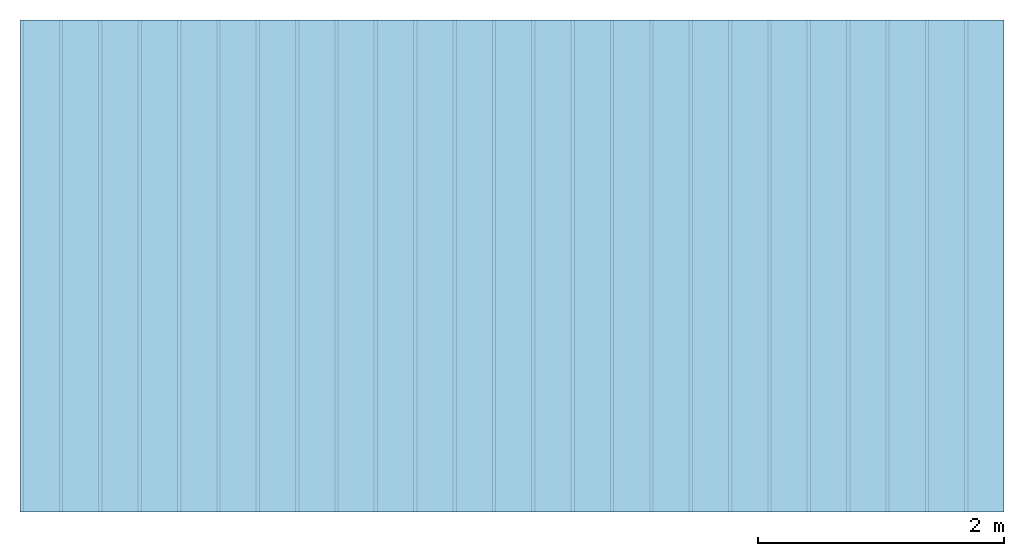
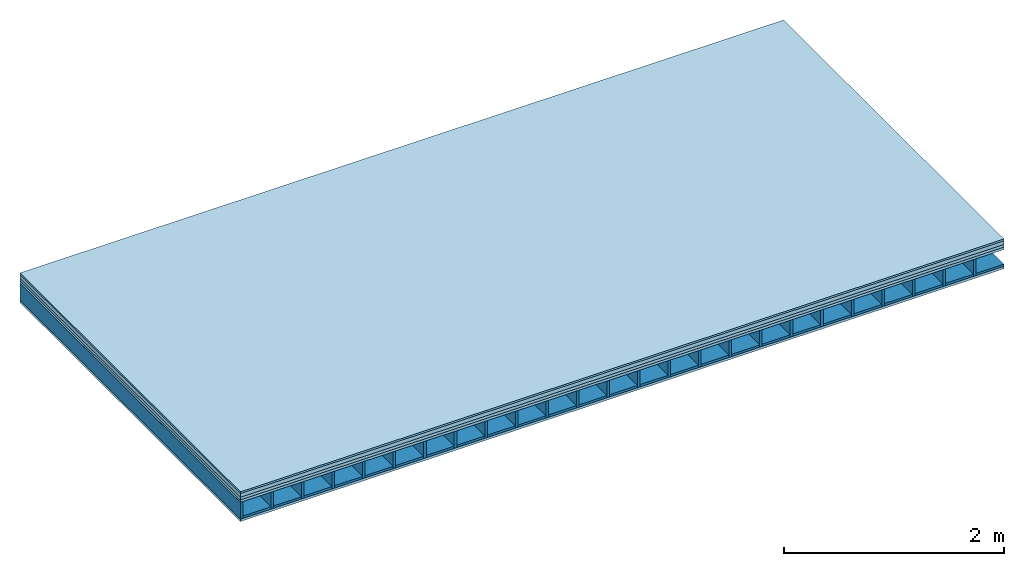
# One storey: 5 plates, 2 members, 1 element without a shape of its own.
"""IFC4 building model written with IfcOpenShell, lengths in metres."""

from ifc_helpers import new_model, si_unit, derived_unit, direction, frame, frame_2d, origin, origin_with_axes, place, context, project, spatial, rectangle, extrude, material, layer, layer_set, type_object, element, aggregate, save


model = new_model("IFC4")

# Units and contexts
plan_context = context("Plan", 3, precision=1e-05, world=origin(), true_north=direction((0.0, 1.0)))
model_context = context("Model", 3, precision=1e-05, world=origin(), true_north=direction((0.0, 1.0)))
ifc_project = project(units=[si_unit("LENGTHUNIT", "METRE"), derived_unit("SOUNDPRESSUREUNIT", [(si_unit("PRESSUREUNIT", "PASCAL", prefix="MICRO"), 0)]), si_unit("ENERGYUNIT", "JOULE", prefix="MEGA"), si_unit("MASSUNIT", "GRAM", prefix="KILO"), derived_unit("THERMALTRANSMITTANCEUNIT", [(si_unit("POWERUNIT", "WATT"), 1), (si_unit("AREAUNIT", "SQUARE_METRE"), -1), (si_unit("THERMODYNAMICTEMPERATUREUNIT", "KELVIN"), -1)]), derived_unit("AREADENSITYUNIT", [(si_unit("MASSUNIT", "GRAM", prefix="KILO"), 1), (si_unit("AREAUNIT", "SQUARE_METRE"), -1)]), derived_unit("USERDEFINED", [(si_unit("ENERGYUNIT", "JOULE", prefix="MEGA"), 1), (si_unit("AREAUNIT", "SQUARE_METRE"), -1)])], contexts=[plan_context, model_context])

# Site, building, storey
site = spatial("IfcSite", under=ifc_project)
building_placement = place(None, origin())
building = spatial("IfcBuilding", under=site, at=building_placement)
storey_placement = place(building_placement, origin())
storey = spatial("IfcBuildingStorey", under=building, at=storey_placement)

# Slab, members, plates
ifc_material_1 = material(Category="03.007")
ifc_layer_1 = layer(ifc_material_1, 0.02, Name="On-material")
ifc_material_2 = material(Name="internal", Category="10.009")
ifc_layer_2 = layer(ifc_material_2, 0.04, Name="Impact sound insulation")
ifc_material_3 = material(Name="with broken")
ifc_layer_3 = layer(ifc_material_3, 0.03, Name="on Supporting structure")
ifc_material_4 = material(Name="3-layer board Spruce Nova Top", Category="07.001")
ifc_layer_4 = layer(ifc_material_4, 0.027, Name="Sub-floor")
ifc_material_5 = material(Name="Rigid, of the art")
ifc_layer_5 = layer(ifc_material_5, 0.0, Name="Bond")
ifc_layer_6 = layer(None, 0.186, Name="Supporting structure")
ifc_layer_7 = layer(ifc_material_5, 0.0, Name="Bond")
ifc_layer_8 = layer(ifc_material_4, 0.027, Name="Lower layer 1")
ifc_layer_set = layer_set([ifc_layer_1, ifc_layer_2, ifc_layer_3, ifc_layer_4, ifc_layer_5, ifc_layer_6, ifc_layer_7, ifc_layer_8])
slab_type = type_object("IfcSlabType", Name="A0015", PredefinedType="NOTDEFINED", material=ifc_layer_set)
slab_placement = place(None, frame((0.0, 0.0, 0.0), z_axis=(0.0, 0.0, -1.0), x_axis=(1.0, 0.0, 0.0)))
slab = element("IfcSlab", 1, at=slab_placement, inside=storey, type_object=slab_type, material=ifc_layer_set, Name="Slab #1")
ifc_material_6 = material()
member_1_placement = place(slab_placement, origin())
member_1 = element("IfcMember", 2, at=member_1_placement, material=ifc_material_6, Name="Supporting structure", context=plan_context, shape_type="SweptSolid", body=[
    extrude(rectangle(XDim=0.027, YDim=0.186, at=frame_2d((0.0135, 0.093), x_axis=(1.0, 0.0))), frame((0.0, 4.0, 0.117), z_axis=(0.0, -1.0, 0.0), x_axis=(1.0, 0.0, 0.0)), (0.0, 0.0, 1.0), 4.0),
    extrude(rectangle(XDim=0.027, YDim=0.186, at=frame_2d((0.0135, 0.093), x_axis=(1.0, 0.0))), frame((0.32, 4.0, 0.117), z_axis=(0.0, -1.0, 0.0), x_axis=(1.0, 0.0, 0.0)), (0.0, 0.0, 1.0), 4.0),
    extrude(rectangle(XDim=0.027, YDim=0.186, at=frame_2d((0.0135, 0.093), x_axis=(1.0, 0.0))), frame((0.64, 4.0, 0.117), z_axis=(0.0, -1.0, 0.0), x_axis=(1.0, 0.0, 0.0)), (0.0, 0.0, 1.0), 4.0),
    extrude(rectangle(XDim=0.027, YDim=0.186, at=frame_2d((0.0135, 0.093), x_axis=(1.0, 0.0))), frame((0.96, 4.0, 0.117), z_axis=(0.0, -1.0, 0.0), x_axis=(1.0, 0.0, 0.0)), (0.0, 0.0, 1.0), 4.0),
    extrude(rectangle(XDim=0.027, YDim=0.186, at=frame_2d((0.0135, 0.093), x_axis=(1.0, 0.0))), frame((1.28, 4.0, 0.117), z_axis=(0.0, -1.0, 0.0), x_axis=(1.0, 0.0, 0.0)), (0.0, 0.0, 1.0), 4.0),
    extrude(rectangle(XDim=0.027, YDim=0.186, at=frame_2d((0.0135, 0.093), x_axis=(1.0, 0.0))), frame((1.6, 4.0, 0.117), z_axis=(0.0, -1.0, 0.0), x_axis=(1.0, 0.0, 0.0)), (0.0, 0.0, 1.0), 4.0),
    extrude(rectangle(XDim=0.027, YDim=0.186, at=frame_2d((0.0135, 0.093), x_axis=(1.0, 0.0))), frame((1.92, 4.0, 0.117), z_axis=(0.0, -1.0, 0.0), x_axis=(1.0, 0.0, 0.0)), (0.0, 0.0, 1.0), 4.0),
    extrude(rectangle(XDim=0.027, YDim=0.186, at=frame_2d((0.0135, 0.093), x_axis=(1.0, 0.0))), frame((2.24, 4.0, 0.117), z_axis=(0.0, -1.0, 0.0), x_axis=(1.0, 0.0, 0.0)), (0.0, 0.0, 1.0), 4.0),
    extrude(rectangle(XDim=0.027, YDim=0.186, at=frame_2d((0.0135, 0.093), x_axis=(1.0, 0.0))), frame((2.56, 4.0, 0.117), z_axis=(0.0, -1.0, 0.0), x_axis=(1.0, 0.0, 0.0)), (0.0, 0.0, 1.0), 4.0),
    extrude(rectangle(XDim=0.027, YDim=0.186, at=frame_2d((0.0135, 0.093), x_axis=(1.0, 0.0))), frame((2.88, 4.0, 0.117), z_axis=(0.0, -1.0, 0.0), x_axis=(1.0, 0.0, 0.0)), (0.0, 0.0, 1.0), 4.0),
    extrude(rectangle(XDim=0.027, YDim=0.186, at=frame_2d((0.0135, 0.093), x_axis=(1.0, 0.0))), frame((3.2, 4.0, 0.117), z_axis=(0.0, -1.0, 0.0), x_axis=(1.0, 0.0, 0.0)), (0.0, 0.0, 1.0), 4.0),
    extrude(rectangle(XDim=0.027, YDim=0.186, at=frame_2d((0.0135, 0.093), x_axis=(1.0, 0.0))), frame((3.52, 4.0, 0.117), z_axis=(0.0, -1.0, 0.0), x_axis=(1.0, 0.0, 0.0)), (0.0, 0.0, 1.0), 4.0),
    extrude(rectangle(XDim=0.027, YDim=0.186, at=frame_2d((0.0135, 0.093), x_axis=(1.0, 0.0))), frame((3.84, 4.0, 0.117), z_axis=(0.0, -1.0, 0.0), x_axis=(1.0, 0.0, 0.0)), (0.0, 0.0, 1.0), 4.0),
    extrude(rectangle(XDim=0.027, YDim=0.186, at=frame_2d((0.0135, 0.093), x_axis=(1.0, 0.0))), frame((4.16, 4.0, 0.117), z_axis=(0.0, -1.0, 0.0), x_axis=(1.0, 0.0, 0.0)), (0.0, 0.0, 1.0), 4.0),
    extrude(rectangle(XDim=0.027, YDim=0.186, at=frame_2d((0.0135, 0.093), x_axis=(1.0, 0.0))), frame((4.48, 4.0, 0.117), z_axis=(0.0, -1.0, 0.0), x_axis=(1.0, 0.0, 0.0)), (0.0, 0.0, 1.0), 4.0),
    extrude(rectangle(XDim=0.027, YDim=0.186, at=frame_2d((0.0135, 0.093), x_axis=(1.0, 0.0))), frame((4.8, 4.0, 0.117), z_axis=(0.0, -1.0, 0.0), x_axis=(1.0, 0.0, 0.0)), (0.0, 0.0, 1.0), 4.0),
    extrude(rectangle(XDim=0.027, YDim=0.186, at=frame_2d((0.0135, 0.093), x_axis=(1.0, 0.0))), frame((5.12, 4.0, 0.117), z_axis=(0.0, -1.0, 0.0), x_axis=(1.0, 0.0, 0.0)), (0.0, 0.0, 1.0), 4.0),
    extrude(rectangle(XDim=0.027, YDim=0.186, at=frame_2d((0.0135, 0.093), x_axis=(1.0, 0.0))), frame((5.44, 4.0, 0.117), z_axis=(0.0, -1.0, 0.0), x_axis=(1.0, 0.0, 0.0)), (0.0, 0.0, 1.0), 4.0),
    extrude(rectangle(XDim=0.027, YDim=0.186, at=frame_2d((0.0135, 0.093), x_axis=(1.0, 0.0))), frame((5.76, 4.0, 0.117), z_axis=(0.0, -1.0, 0.0), x_axis=(1.0, 0.0, 0.0)), (0.0, 0.0, 1.0), 4.0),
    extrude(rectangle(XDim=0.027, YDim=0.186, at=frame_2d((0.0135, 0.093), x_axis=(1.0, 0.0))), frame((6.08, 4.0, 0.117), z_axis=(0.0, -1.0, 0.0), x_axis=(1.0, 0.0, 0.0)), (0.0, 0.0, 1.0), 4.0),
    extrude(rectangle(XDim=0.027, YDim=0.186, at=frame_2d((0.0135, 0.093), x_axis=(1.0, 0.0))), frame((6.4, 4.0, 0.117), z_axis=(0.0, -1.0, 0.0), x_axis=(1.0, 0.0, 0.0)), (0.0, 0.0, 1.0), 4.0),
    extrude(rectangle(XDim=0.027, YDim=0.186, at=frame_2d((0.0135, 0.093), x_axis=(1.0, 0.0))), frame((6.72, 4.0, 0.117), z_axis=(0.0, -1.0, 0.0), x_axis=(1.0, 0.0, 0.0)), (0.0, 0.0, 1.0), 4.0),
    extrude(rectangle(XDim=0.027, YDim=0.186, at=frame_2d((0.0135, 0.093), x_axis=(1.0, 0.0))), frame((7.04, 4.0, 0.117), z_axis=(0.0, -1.0, 0.0), x_axis=(1.0, 0.0, 0.0)), (0.0, 0.0, 1.0), 4.0),
    extrude(rectangle(XDim=0.027, YDim=0.186, at=frame_2d((0.0135, 0.093), x_axis=(1.0, 0.0))), frame((7.36, 4.0, 0.117), z_axis=(0.0, -1.0, 0.0), x_axis=(1.0, 0.0, 0.0)), (0.0, 0.0, 1.0), 4.0),
    extrude(rectangle(XDim=0.027, YDim=0.186, at=frame_2d((0.0135, 0.093), x_axis=(1.0, 0.0))), frame((7.68, 4.0, 0.117), z_axis=(0.0, -1.0, 0.0), x_axis=(1.0, 0.0, 0.0)), (0.0, 0.0, 1.0), 4.0),
])
ifc_material_7 = material(Name="Gravel of lime 3-6 mm")
member_2_placement = place(slab_placement, origin())
member_2 = element("IfcMember", 3, at=member_2_placement, material=ifc_material_7, Name="in supporting structure", context=plan_context, shape_type="SweptSolid", body=[
    extrude(rectangle(XDim=0.293, YDim=0.025, at=frame_2d((0.1465, 0.0125), x_axis=(1.0, 0.0))), frame((0.027, 4.0, 0.278), z_axis=(0.0, -1.0, 0.0), x_axis=(1.0, 0.0, 0.0)), (0.0, 0.0, 1.0), 4.0),
    extrude(rectangle(XDim=0.293, YDim=0.025, at=frame_2d((0.1465, 0.0125), x_axis=(1.0, 0.0))), frame((0.347, 4.0, 0.278), z_axis=(0.0, -1.0, 0.0), x_axis=(1.0, 0.0, 0.0)), (0.0, 0.0, 1.0), 4.0),
    extrude(rectangle(XDim=0.293, YDim=0.025, at=frame_2d((0.1465, 0.0125), x_axis=(1.0, 0.0))), frame((0.667, 4.0, 0.278), z_axis=(0.0, -1.0, 0.0), x_axis=(1.0, 0.0, 0.0)), (0.0, 0.0, 1.0), 4.0),
    extrude(rectangle(XDim=0.293, YDim=0.025, at=frame_2d((0.1465, 0.0125), x_axis=(1.0, 0.0))), frame((0.987, 4.0, 0.278), z_axis=(0.0, -1.0, 0.0), x_axis=(1.0, 0.0, 0.0)), (0.0, 0.0, 1.0), 4.0),
    extrude(rectangle(XDim=0.293, YDim=0.025, at=frame_2d((0.1465, 0.0125), x_axis=(1.0, 0.0))), frame((1.307, 4.0, 0.278), z_axis=(0.0, -1.0, 0.0), x_axis=(1.0, 0.0, 0.0)), (0.0, 0.0, 1.0), 4.0),
    extrude(rectangle(XDim=0.293, YDim=0.025, at=frame_2d((0.1465, 0.0125), x_axis=(1.0, 0.0))), frame((1.627, 4.0, 0.278), z_axis=(0.0, -1.0, 0.0), x_axis=(1.0, 0.0, 0.0)), (0.0, 0.0, 1.0), 4.0),
    extrude(rectangle(XDim=0.293, YDim=0.025, at=frame_2d((0.1465, 0.0125), x_axis=(1.0, 0.0))), frame((1.947, 4.0, 0.278), z_axis=(0.0, -1.0, 0.0), x_axis=(1.0, 0.0, 0.0)), (0.0, 0.0, 1.0), 4.0),
    extrude(rectangle(XDim=0.293, YDim=0.025, at=frame_2d((0.1465, 0.0125), x_axis=(1.0, 0.0))), frame((2.267, 4.0, 0.278), z_axis=(0.0, -1.0, 0.0), x_axis=(1.0, 0.0, 0.0)), (0.0, 0.0, 1.0), 4.0),
    extrude(rectangle(XDim=0.293, YDim=0.025, at=frame_2d((0.1465, 0.0125), x_axis=(1.0, 0.0))), frame((2.587, 4.0, 0.278), z_axis=(0.0, -1.0, 0.0), x_axis=(1.0, 0.0, 0.0)), (0.0, 0.0, 1.0), 4.0),
    extrude(rectangle(XDim=0.293, YDim=0.025, at=frame_2d((0.1465, 0.0125), x_axis=(1.0, 0.0))), frame((2.907, 4.0, 0.278), z_axis=(0.0, -1.0, 0.0), x_axis=(1.0, 0.0, 0.0)), (0.0, 0.0, 1.0), 4.0),
    extrude(rectangle(XDim=0.293, YDim=0.025, at=frame_2d((0.1465, 0.0125), x_axis=(1.0, 0.0))), frame((3.227, 4.0, 0.278), z_axis=(0.0, -1.0, 0.0), x_axis=(1.0, 0.0, 0.0)), (0.0, 0.0, 1.0), 4.0),
    extrude(rectangle(XDim=0.293, YDim=0.025, at=frame_2d((0.1465, 0.0125), x_axis=(1.0, 0.0))), frame((3.547, 4.0, 0.278), z_axis=(0.0, -1.0, 0.0), x_axis=(1.0, 0.0, 0.0)), (0.0, 0.0, 1.0), 4.0),
    extrude(rectangle(XDim=0.293, YDim=0.025, at=frame_2d((0.1465, 0.0125), x_axis=(1.0, 0.0))), frame((3.867, 4.0, 0.278), z_axis=(0.0, -1.0, 0.0), x_axis=(1.0, 0.0, 0.0)), (0.0, 0.0, 1.0), 4.0),
    extrude(rectangle(XDim=0.293, YDim=0.025, at=frame_2d((0.1465, 0.0125), x_axis=(1.0, 0.0))), frame((4.187, 4.0, 0.278), z_axis=(0.0, -1.0, 0.0), x_axis=(1.0, 0.0, 0.0)), (0.0, 0.0, 1.0), 4.0),
    extrude(rectangle(XDim=0.293, YDim=0.025, at=frame_2d((0.1465, 0.0125), x_axis=(1.0, 0.0))), frame((4.507, 4.0, 0.278), z_axis=(0.0, -1.0, 0.0), x_axis=(1.0, 0.0, 0.0)), (0.0, 0.0, 1.0), 4.0),
    extrude(rectangle(XDim=0.293, YDim=0.025, at=frame_2d((0.1465, 0.0125), x_axis=(1.0, 0.0))), frame((4.827, 4.0, 0.278), z_axis=(0.0, -1.0, 0.0), x_axis=(1.0, 0.0, 0.0)), (0.0, 0.0, 1.0), 4.0),
    extrude(rectangle(XDim=0.293, YDim=0.025, at=frame_2d((0.1465, 0.0125), x_axis=(1.0, 0.0))), frame((5.147, 4.0, 0.278), z_axis=(0.0, -1.0, 0.0), x_axis=(1.0, 0.0, 0.0)), (0.0, 0.0, 1.0), 4.0),
    extrude(rectangle(XDim=0.293, YDim=0.025, at=frame_2d((0.1465, 0.0125), x_axis=(1.0, 0.0))), frame((5.467, 4.0, 0.278), z_axis=(0.0, -1.0, 0.0), x_axis=(1.0, 0.0, 0.0)), (0.0, 0.0, 1.0), 4.0),
    extrude(rectangle(XDim=0.293, YDim=0.025, at=frame_2d((0.1465, 0.0125), x_axis=(1.0, 0.0))), frame((5.787, 4.0, 0.278), z_axis=(0.0, -1.0, 0.0), x_axis=(1.0, 0.0, 0.0)), (0.0, 0.0, 1.0), 4.0),
    extrude(rectangle(XDim=0.293, YDim=0.025, at=frame_2d((0.1465, 0.0125), x_axis=(1.0, 0.0))), frame((6.107, 4.0, 0.278), z_axis=(0.0, -1.0, 0.0), x_axis=(1.0, 0.0, 0.0)), (0.0, 0.0, 1.0), 4.0),
    extrude(rectangle(XDim=0.293, YDim=0.025, at=frame_2d((0.1465, 0.0125), x_axis=(1.0, 0.0))), frame((6.427, 4.0, 0.278), z_axis=(0.0, -1.0, 0.0), x_axis=(1.0, 0.0, 0.0)), (0.0, 0.0, 1.0), 4.0),
    extrude(rectangle(XDim=0.293, YDim=0.025, at=frame_2d((0.1465, 0.0125), x_axis=(1.0, 0.0))), frame((6.747, 4.0, 0.278), z_axis=(0.0, -1.0, 0.0), x_axis=(1.0, 0.0, 0.0)), (0.0, 0.0, 1.0), 4.0),
    extrude(rectangle(XDim=0.293, YDim=0.025, at=frame_2d((0.1465, 0.0125), x_axis=(1.0, 0.0))), frame((7.067, 4.0, 0.278), z_axis=(0.0, -1.0, 0.0), x_axis=(1.0, 0.0, 0.0)), (0.0, 0.0, 1.0), 4.0),
    extrude(rectangle(XDim=0.293, YDim=0.025, at=frame_2d((0.1465, 0.0125), x_axis=(1.0, 0.0))), frame((7.387, 4.0, 0.278), z_axis=(0.0, -1.0, 0.0), x_axis=(1.0, 0.0, 0.0)), (0.0, 0.0, 1.0), 4.0),
    extrude(rectangle(XDim=0.293, YDim=0.025, at=frame_2d((0.1465, 0.0125), x_axis=(1.0, 0.0))), frame((7.707, 4.0, 0.278), z_axis=(0.0, -1.0, 0.0), x_axis=(1.0, 0.0, 0.0)), (0.0, 0.0, 1.0), 4.0),
])
plate_1_placement = place(slab_placement, origin())
plate_1 = element("IfcPlate", 4, at=plate_1_placement, material=ifc_material_1, Name="On-material", context=plan_context, shape_type="SweptSolid", body=[
    extrude(rectangle(XDim=8.0, YDim=4.0, at=frame_2d((4.0, 2.0), x_axis=(1.0, 0.0))), origin_with_axes(), (0.0, 0.0, 1.0), 0.02),
])
plate_2_placement = place(slab_placement, origin())
plate_2 = element("IfcPlate", 5, at=plate_2_placement, material=ifc_material_2, Name="Impact sound insulation", context=plan_context, shape_type="SweptSolid", body=[
    extrude(rectangle(XDim=8.0, YDim=4.0, at=frame_2d((4.0, 2.0), x_axis=(1.0, 0.0))), frame((0.0, 0.0, 0.02), z_axis=(0.0, 0.0, 1.0), x_axis=(1.0, 0.0, 0.0)), (0.0, 0.0, 1.0), 0.04),
])
plate_3_placement = place(slab_placement, origin())
plate_3 = element("IfcPlate", 6, at=plate_3_placement, material=ifc_material_3, Name="on Supporting structure", context=plan_context, shape_type="SweptSolid", body=[
    extrude(rectangle(XDim=8.0, YDim=4.0, at=frame_2d((4.0, 2.0), x_axis=(1.0, 0.0))), frame((0.0, 0.0, 0.06), z_axis=(0.0, 0.0, 1.0), x_axis=(1.0, 0.0, 0.0)), (0.0, 0.0, 1.0), 0.03),
])
plate_4_placement = place(slab_placement, origin())
plate_4 = element("IfcPlate", 7, at=plate_4_placement, material=ifc_material_4, Name="Sub-floor", context=plan_context, shape_type="SweptSolid", body=[
    extrude(rectangle(XDim=8.0, YDim=4.0, at=frame_2d((4.0, 2.0), x_axis=(1.0, 0.0))), frame((0.0, 0.0, 0.09), z_axis=(0.0, 0.0, 1.0), x_axis=(1.0, 0.0, 0.0)), (0.0, 0.0, 1.0), 0.027),
])
plate_5_placement = place(slab_placement, origin())
plate_5 = element("IfcPlate", 8, at=plate_5_placement, material=ifc_material_4, Name="Lower layer 1", context=plan_context, shape_type="SweptSolid", body=[
    extrude(rectangle(XDim=8.0, YDim=4.0, at=frame_2d((4.0, 2.0), x_axis=(1.0, 0.0))), frame((0.0, 0.0, 0.303), z_axis=(0.0, 0.0, 1.0), x_axis=(1.0, 0.0, 0.0)), (0.0, 0.0, 1.0), 0.027),
])
aggregate(slab, [plate_1, plate_2, plate_3, plate_4, member_1, member_2, plate_5])

save(model, "model.ifc")
